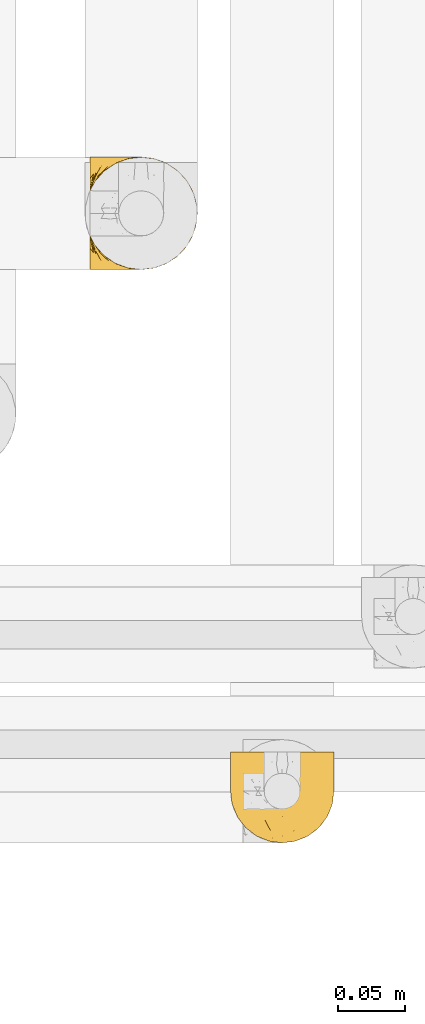
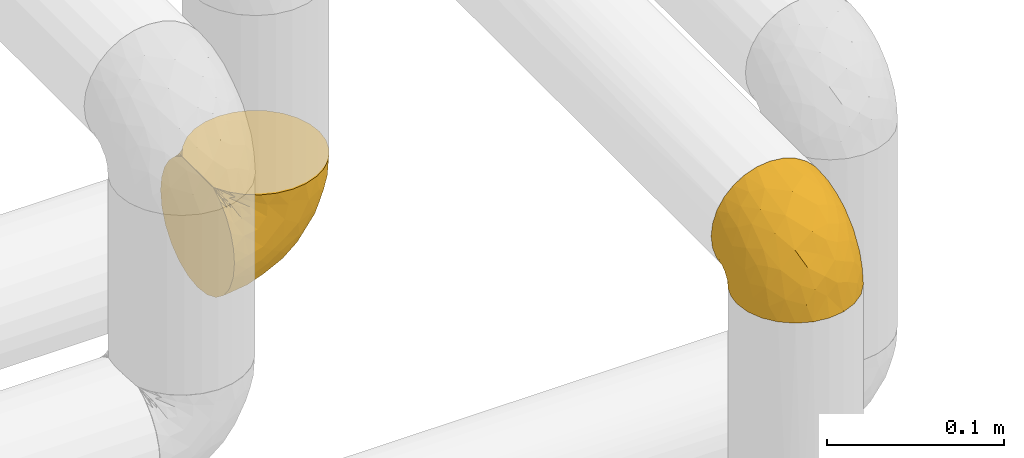
# One storey, part 91 of 827: 2 coverings.
"""IFC2X3 building model written with IfcOpenShell, lengths in millimetres."""

from ifc_helpers import new_model, entity, si_unit, converted_unit, derived_unit, direction, frame, origin, place, context, subcontext, project, spatial, faceted_brep, element, save


model = new_model("IFC2X3")

# Units and contexts
model_context = context("Model", 3, precision=0.01, world=origin(), true_north=direction((6.12303176911189e-17, 1.0)))
body_context = subcontext(model_context, "Body", "Model", "MODEL_VIEW")
ifc_project = project(units=[si_unit("LENGTHUNIT", "METRE", prefix="MILLI"), si_unit("AREAUNIT", "SQUARE_METRE"), si_unit("VOLUMEUNIT", "CUBIC_METRE"), converted_unit("PLANEANGLEUNIT", "DEGREE", entity("IfcRatioMeasure", 0.0174532925199433), si_unit("PLANEANGLEUNIT", "RADIAN"), dimensions=[0, 0, 0, 0, 0, 0, 0]), si_unit("MASSUNIT", "GRAM", prefix="KILO"), derived_unit("MASSDENSITYUNIT", [(si_unit("MASSUNIT", "GRAM", prefix="KILO"), 1), (si_unit("LENGTHUNIT", "METRE"), -3)]), derived_unit("MOMENTOFINERTIAUNIT", [(si_unit("LENGTHUNIT", "METRE"), 4)]), si_unit("TIMEUNIT", "SECOND"), si_unit("FREQUENCYUNIT", "HERTZ"), si_unit("THERMODYNAMICTEMPERATUREUNIT", "DEGREE_CELSIUS"), derived_unit("THERMALTRANSMITTANCEUNIT", [(si_unit("MASSUNIT", "GRAM", prefix="KILO"), 1), (si_unit("THERMODYNAMICTEMPERATUREUNIT", "KELVIN"), -1), (si_unit("TIMEUNIT", "SECOND"), -3)]), derived_unit("VOLUMETRICFLOWRATEUNIT", [(si_unit("LENGTHUNIT", "METRE"), 3), (si_unit("TIMEUNIT", "SECOND"), -1)]), derived_unit("MASSFLOWRATEUNIT", [(si_unit("MASSUNIT", "GRAM", prefix="KILO"), 1), (si_unit("TIMEUNIT", "SECOND"), -1)]), derived_unit("ROTATIONALFREQUENCYUNIT", [(si_unit("TIMEUNIT", "SECOND"), -1)]), si_unit("ELECTRICCURRENTUNIT", "AMPERE"), si_unit("ELECTRICVOLTAGEUNIT", "VOLT"), si_unit("POWERUNIT", "WATT"), si_unit("FORCEUNIT", "NEWTON", prefix="KILO"), si_unit("ILLUMINANCEUNIT", "LUX"), si_unit("LUMINOUSFLUXUNIT", "LUMEN"), si_unit("LUMINOUSINTENSITYUNIT", "CANDELA"), derived_unit("USERDEFINED", [(si_unit("MASSUNIT", "GRAM", prefix="KILO"), -1), (si_unit("LENGTHUNIT", "METRE"), -2), (si_unit("TIMEUNIT", "SECOND"), 3), (si_unit("LUMINOUSFLUXUNIT", "LUMEN"), 1)]), derived_unit("LINEARVELOCITYUNIT", [(si_unit("LENGTHUNIT", "METRE"), 1), (si_unit("TIMEUNIT", "SECOND"), -1)]), si_unit("PRESSUREUNIT", "PASCAL"), derived_unit("USERDEFINED", [(si_unit("LENGTHUNIT", "METRE"), -2), (si_unit("MASSUNIT", "GRAM", prefix="KILO"), 1), (si_unit("TIMEUNIT", "SECOND"), -2)]), derived_unit("LINEARFORCEUNIT", [(si_unit("MASSUNIT", "GRAM", prefix="KILO"), 1), (si_unit("LENGTHUNIT", "METRE"), 1), (si_unit("TIMEUNIT", "SECOND"), -2), (si_unit("LENGTHUNIT", "METRE"), -1)]), derived_unit("PLANARFORCEUNIT", [(si_unit("MASSUNIT", "GRAM", prefix="KILO"), 1), (si_unit("LENGTHUNIT", "METRE"), 1), (si_unit("TIMEUNIT", "SECOND"), -2), (si_unit("LENGTHUNIT", "METRE"), -2)])], contexts=[model_context])

# Site, building, storey
site_placement = place(None, origin())
site = spatial("IfcSite", under=ifc_project, at=site_placement, CompositionType="ELEMENT")
building_placement = place(site_placement, origin())
building = spatial("IfcBuilding", under=site, at=building_placement, CompositionType="ELEMENT")
storey_placement = place(building_placement, frame((0.0, 0.0, 28200.0)))
storey = spatial("IfcBuildingStorey", under=building, at=storey_placement, Name="08", CompositionType="ELEMENT", Elevation=28200.0)

# Coverings
covering_1_placement = place(storey_placement, frame((18545.51, 12779.95, 2569.3)))
element("IfcCovering", 1, at=covering_1_placement, inside=storey, Name=":ADSK_", ObjectType=":ADSK_", PredefinedType="INSULATION", context=body_context, shape_type="Brep", body=[
    faceted_brep([(5.41, 69.15, 47.38), (9.99, 69.15, 54.67), (16.08, 69.15, 60.76), (23.37, 69.15, 65.34), (31.49, 69.15, 68.18), (40.05, 69.15, 69.15), (48.61, 69.15, 68.18), (56.73, 69.15, 65.33), (64.02, 69.15, 60.75), (70.11, 69.15, 54.66), (74.69, 69.15, 47.37), (77.53, 69.15, 39.25), (78.5, 69.15, 30.7), (77.63, 69.15, 22.59), (75.08, 69.15, 14.86), (70.97, 69.15, 7.84), (65.47, 69.15, 1.85), (63.27, 69.15, 1.85), (61.53, 69.15, 1.85), (59.57, 69.15, 1.85), (57.6, 69.15, 1.85), (55.63, 69.15, 1.85), (53.67, 69.15, 1.85), (51.7, 69.15, 1.85), (49.73, 69.15, 1.85), (47.54, 69.15, 1.85), (45.34, 69.15, 1.85), (43.15, 69.15, 1.85), (40.96, 69.15, 1.85), (38.76, 69.15, 1.85), (36.57, 69.15, 1.85), (34.37, 69.15, 1.85), (32.18, 69.15, 1.85), (29.98, 69.15, 1.85), (27.79, 69.15, 1.85), (25.6, 69.15, 1.85), (23.4, 69.15, 1.85), (21.21, 69.15, 1.85), (19.01, 69.15, 1.85), (16.82, 69.15, 1.85), (14.62, 69.15, 1.85), (9.12, 69.15, 7.85), (5.0, 69.15, 14.88), (2.46, 69.15, 22.61), (1.6, 69.15, 30.7), (2.56, 69.15, 39.26), (65.47, 68.89, 1.6), (70.97, 62.89, 1.6), (75.09, 55.87, 1.6), (77.63, 48.14, 1.6), (78.5, 40.05, 1.6), (77.19, 30.09, 1.6), (73.34, 20.82, 1.6), (67.23, 12.86, 1.6), (59.27, 6.75, 1.6), (50.0, 2.91, 1.6), (40.05, 1.6, 1.6), (30.09, 2.91, 1.6), (20.82, 6.75, 1.6), (12.86, 12.86, 1.6), (6.75, 20.82, 1.6), (2.91, 30.09, 1.6), (1.6, 40.05, 1.6), (2.46, 48.14, 1.6), (5.0, 55.87, 1.6), (9.12, 62.89, 1.6), (14.62, 68.89, 1.6), (16.82, 68.89, 1.6), (17.8, 68.89, 1.6), (19.39, 68.89, 1.6), (20.98, 68.89, 1.6), (22.57, 68.89, 1.6), (24.16, 68.89, 1.6), (25.75, 68.89, 1.6), (27.33, 68.89, 1.6), (28.92, 68.89, 1.6), (30.51, 68.89, 1.6), (32.1, 68.89, 1.6), (33.69, 68.89, 1.6), (35.28, 68.89, 1.6), (36.87, 68.89, 1.6), (38.46, 68.89, 1.6), (40.05, 68.89, 1.6), (41.63, 68.89, 1.6), (43.22, 68.89, 1.6), (44.81, 68.89, 1.6), (46.4, 68.89, 1.6), (47.99, 68.89, 1.6), (49.58, 68.89, 1.6), (51.17, 68.89, 1.6), (52.76, 68.89, 1.6), (54.72, 68.89, 1.6), (56.69, 68.89, 1.6), (58.88, 68.89, 1.6), (61.08, 68.89, 1.6), (63.27, 68.89, 1.6), (37.77, 68.97, 1.78), (36.07, 68.96, 1.77), (32.96, 68.97, 1.78), (31.36, 68.97, 1.77), (56.52, 68.98, 1.79), (54.96, 68.97, 1.78), (18.75, 68.96, 1.76), (58.07, 68.96, 1.77), (50.37, 68.96, 1.77), (23.36, 68.96, 1.76), (24.95, 68.96, 1.77), (42.43, 68.96, 1.77), (15.97, 69.0, 1.8), (51.96, 68.96, 1.76), (53.47, 68.96, 1.77), (48.63, 68.97, 1.78), (63.93, 68.96, 1.77), (40.93, 68.96, 1.77), (29.72, 68.96, 1.76), (62.4, 68.97, 1.77), (60.92, 68.97, 1.78), (17.31, 68.97, 1.77), (21.74, 68.96, 1.77), (34.56, 68.96, 1.77), (20.18, 68.97, 1.78), (14.62, 68.97, 1.77), (14.62, 69.02, 1.8), (14.62, 69.08, 1.82), (65.47, 68.97, 1.77), (65.47, 68.94, 1.72), (59.5, 68.96, 1.76), (47.1, 68.96, 1.77), (45.61, 68.95, 1.76), (28.18, 68.96, 1.77), (14.62, 68.92, 1.66), (14.62, 68.94, 1.72), (26.61, 68.98, 1.78), (65.47, 69.08, 1.82), (65.47, 69.02, 1.8), (39.32, 68.96, 1.77), (44.12, 68.97, 1.78), (65.47, 68.92, 1.66), (72.26, 61.33, 3.72), (76.57, 53.1, 7.41), (71.77, 63.33, 6.13), (77.9, 55.53, 19.34), (76.56, 63.33, 17.64), (78.5, 54.6, 26.8), (78.5, 41.99, 8.87), (75.52, 57.07, 9.2), (76.13, 57.95, 12.79), (77.81, 51.56, 14.62), (78.5, 41.58, 7.34), (72.4, 61.7, 5.33), (71.77, 65.0, 7.7), (72.25, 67.02, 9.41), (78.5, 61.87, 28.75), (78.5, 49.27, 21.47), (78.5, 43.94, 16.15), (75.75, 61.21, 14.14), (78.5, 63.4, 29.16), (50.46, 33.11, 57.02), (52.75, 52.82, 64.92), (40.05, 43.3, 64.0), (77.7, 33.73, 11.92), (77.66, 36.52, 19.16), (71.02, 24.87, 28.65), (63.45, 14.17, 24.62), (70.55, 18.43, 15.19), (75.57, 28.67, 18.36), (75.57, 26.0, 9.2), (72.61, 49.25, 46.98), (72.61, 59.72, 50.24), (67.24, 55.1, 56.1), (77.74, 44.72, 28.97), (57.43, 34.15, 54.46), (47.19, 5.25, 21.34), (54.76, 6.75, 18.4), (40.05, 55.54, 66.44), (63.45, 10.47, 12.07), (60.1, 25.49, 45.49), (63.72, 35.53, 50.57), (76.83, 48.22, 36.04), (76.34, 58.71, 42.07), (60.51, 57.42, 62.12), (72.59, 34.84, 37.37), (76.05, 36.87, 29.39), (66.15, 45.01, 53.59), (60.51, 44.4, 58.06), (51.88, 23.96, 49.27), (55.34, 11.2, 29.63), (48.67, 10.56, 33.21), (53.89, 16.81, 40.1), (46.73, 17.38, 44.08), (40.05, 21.38, 49.36), (40.05, 32.34, 56.68), (40.05, 4.3, 15.2), (63.95, 20.65, 35.57), (67.24, 29.66, 41.7), (69.62, 39.6, 46.4), (73.6, 42.55, 41.41), (40.05, 6.74, 27.45), (40.05, 14.06, 38.4), (4.52, 26.84, 12.99), (32.72, 5.28, 21.33), (27.18, 18.52, 42.89), (29.63, 33.13, 57.04), (12.86, 55.1, 56.11), (19.59, 57.43, 62.13), (9.54, 20.72, 21.89), (16.64, 11.46, 16.62), (17.48, 17.69, 32.9), (7.49, 49.26, 46.99), (7.49, 59.73, 50.25), (3.75, 58.71, 42.08), (20.75, 29.72, 49.91), (2.33, 35.35, 15.6), (1.6, 43.94, 16.15), (1.6, 41.99, 8.87), (1.6, 63.4, 29.16), (26.94, 4.93, 13.16), (9.54, 17.46, 10.83), (31.21, 10.94, 33.8), (25.33, 8.92, 25.02), (27.35, 52.83, 64.92), (8.17, 29.34, 32.83), (4.3, 30.26, 20.56), (19.59, 44.4, 58.07), (2.23, 39.06, 21.46), (2.45, 43.06, 28.1), (1.6, 54.6, 26.8), (1.6, 49.27, 21.47), (12.86, 42.69, 51.29), (3.27, 48.2, 36.04), (1.6, 61.87, 28.75), (2.29, 33.44, 8.45), (12.86, 29.67, 41.73), (6.89, 38.5, 39.27), (12.43, 23.35, 33.56), (4.1, 34.97, 27.29), (3.53, 53.1, 7.41), (6.88, 59.68, 3.51), (8.16, 62.19, 4.68), (9.02, 64.11, 5.52), (5.0, 57.97, 8.75), (3.96, 57.95, 12.79), (3.52, 63.33, 17.65), (2.4, 51.77, 13.9), (7.83, 67.02, 9.42), (8.32, 64.98, 7.68), (2.19, 55.53, 19.33), (4.34, 61.22, 14.13)], [[[0, 1, 2, 3, 4, 5, 6, 7, 8, 9, 10, 11, 12, 13, 14, 15, 16, 17, 18, 19, 20, 21, 22, 23, 24, 25, 26, 27, 28, 29, 30, 31, 32, 33, 34, 35, 36, 37, 38, 39, 40, 41, 42, 43, 44, 45]], [[46, 47, 48, 49, 50, 51, 52, 53, 54, 55, 56, 57, 58, 59, 60, 61, 62, 63, 64, 65, 66, 67, 68, 69, 70, 71, 72, 73, 74, 75, 76, 77, 78, 79, 80, 81, 82, 83, 84, 85, 86, 87, 88, 89, 90, 91, 92, 93, 94, 95]], [[96, 97, 30]], [[98, 77, 99]], [[100, 101, 21]], [[69, 68, 102]], [[20, 19, 103]], [[24, 23, 104]], [[20, 103, 100]], [[72, 105, 106]], [[84, 83, 107]], [[89, 88, 104]], [[108, 67, 66]], [[109, 110, 90]], [[111, 25, 24]], [[112, 17, 16]], [[82, 113, 83]], [[109, 23, 22]], [[114, 76, 75]], [[105, 36, 106]], [[104, 111, 24]], [[18, 115, 116]], [[97, 96, 80]], [[67, 108, 117]], [[105, 71, 118]], [[31, 97, 119]], [[102, 120, 69]], [[108, 121, 122, 123, 40]], [[112, 95, 115]], [[17, 115, 18]], [[94, 116, 115]], [[117, 68, 67]], [[38, 117, 39]], [[112, 124, 125]], [[17, 112, 115]], [[70, 120, 118]], [[39, 117, 108]], [[120, 38, 37]], [[120, 37, 118]], [[120, 70, 69]], [[116, 94, 126]], [[127, 86, 128]], [[117, 38, 102]], [[74, 129, 75]], [[99, 33, 32]], [[115, 95, 94]], [[39, 108, 40]], [[108, 66, 130, 131]], [[105, 72, 71]], [[118, 37, 36]], [[71, 70, 118]], [[35, 106, 36]], [[36, 105, 118]], [[35, 132, 106]], [[74, 73, 132]], [[106, 132, 73]], [[99, 114, 33]], [[132, 35, 34]], [[73, 72, 106]], [[95, 112, 46]], [[112, 16, 133, 134, 124]], [[129, 114, 75]], [[99, 76, 114]], [[114, 129, 33]], [[34, 33, 129]], [[78, 77, 98]], [[98, 119, 78]], [[129, 132, 34]], [[132, 129, 74]], [[79, 97, 80]], [[98, 99, 32]], [[98, 32, 31]], [[77, 76, 99]], [[97, 79, 119]], [[135, 96, 29]], [[30, 97, 31]], [[135, 29, 28]], [[81, 80, 96]], [[29, 96, 30]], [[31, 119, 98]], [[119, 79, 78]], [[96, 135, 81]], [[82, 81, 135]], [[113, 107, 83]], [[84, 107, 136]], [[107, 27, 136]], [[113, 28, 107]], [[27, 107, 28]], [[85, 84, 136]], [[136, 27, 26]], [[113, 135, 28]], [[135, 113, 82]], [[109, 89, 104]], [[86, 85, 128]], [[89, 109, 90]], [[111, 87, 127]], [[26, 128, 136]], [[88, 111, 104]], [[25, 111, 127]], [[22, 110, 109]], [[23, 109, 104]], [[110, 91, 90]], [[100, 92, 101]], [[110, 22, 101]], [[91, 110, 101]], [[116, 19, 18]], [[111, 88, 87]], [[126, 103, 19]], [[25, 127, 26]], [[86, 127, 87]], [[127, 128, 26]], [[136, 128, 85]], [[120, 102, 38]], [[117, 102, 68]], [[91, 101, 92]], [[21, 101, 22]], [[93, 92, 103]], [[100, 21, 20]], [[100, 103, 92]], [[126, 93, 103]], [[93, 126, 94]], [[116, 126, 19]], [[137, 138, 47]], [[48, 138, 139]], [[140, 125, 124]], [[141, 142, 143]], [[144, 49, 139]], [[145, 140, 146]], [[48, 139, 49]], [[139, 145, 147]], [[49, 144, 148, 50]], [[137, 125, 149]], [[14, 13, 142]], [[150, 146, 140]], [[149, 140, 145]], [[151, 150, 134]], [[151, 14, 142]], [[16, 15, 133]], [[13, 152, 142]], [[124, 150, 140]], [[141, 143, 153]], [[14, 151, 15]], [[15, 151, 133]], [[47, 46, 137]], [[139, 154, 144]], [[138, 48, 47]], [[125, 140, 149]], [[134, 133, 151]], [[146, 155, 141]], [[145, 146, 147]], [[149, 139, 138]], [[147, 153, 154]], [[147, 146, 141]], [[139, 147, 154]], [[139, 149, 145]], [[149, 138, 137]], [[147, 141, 153]], [[146, 150, 155]], [[151, 155, 150]], [[142, 141, 155]], [[13, 12, 156, 152]], [[152, 143, 142]], [[151, 142, 155]], [[150, 124, 134]], [[157, 158, 159]], [[160, 154, 161]], [[162, 163, 164]], [[165, 166, 160]], [[167, 168, 169]], [[153, 170, 161]], [[156, 12, 11]], [[158, 157, 171]], [[172, 55, 173]], [[158, 6, 174]], [[175, 54, 53]], [[52, 166, 164]], [[52, 164, 53]], [[54, 175, 173]], [[166, 52, 51]], [[176, 177, 171]], [[178, 143, 179]], [[156, 11, 179]], [[8, 7, 180]], [[169, 9, 8]], [[179, 143, 152, 156]], [[179, 11, 10]], [[168, 179, 10]], [[181, 162, 182]], [[179, 167, 178]], [[183, 184, 177]], [[183, 169, 184]], [[176, 171, 185]], [[172, 186, 187]], [[158, 7, 6]], [[159, 158, 174]], [[184, 180, 158]], [[54, 173, 55]], [[180, 169, 8]], [[188, 189, 187]], [[9, 168, 10]], [[186, 188, 187]], [[190, 157, 159, 191]], [[55, 172, 192]], [[176, 193, 194]], [[161, 170, 182]], [[162, 164, 165]], [[175, 164, 163]], [[51, 50, 148]], [[167, 195, 196]], [[178, 182, 170]], [[6, 5, 174]], [[158, 180, 7]], [[169, 180, 184]], [[169, 168, 9]], [[179, 168, 167]], [[182, 162, 165]], [[162, 194, 193]], [[161, 165, 160]], [[195, 181, 196]], [[192, 172, 197]], [[192, 56, 55]], [[189, 190, 198]], [[198, 197, 187]], [[172, 187, 197]], [[185, 189, 188]], [[198, 187, 189]], [[186, 172, 173]], [[173, 163, 186]], [[193, 186, 163]], [[176, 185, 188]], [[185, 157, 190]], [[188, 186, 193]], [[177, 176, 194]], [[188, 193, 176]], [[162, 193, 163]], [[195, 177, 194]], [[171, 177, 184]], [[181, 195, 194]], [[183, 167, 169]], [[162, 181, 194]], [[196, 182, 178]], [[158, 171, 184]], [[171, 157, 185]], [[177, 195, 183]], [[167, 183, 195]], [[182, 196, 181]], [[178, 170, 143]], [[178, 167, 196]], [[164, 175, 53]], [[173, 175, 163]], [[160, 51, 148]], [[164, 166, 165]], [[51, 160, 166]], [[160, 148, 144, 154]], [[153, 161, 154]], [[182, 165, 161]], [[190, 189, 185]], [[143, 170, 153]], [[60, 199, 61]], [[197, 200, 192]], [[201, 190, 202]], [[200, 57, 192]], [[203, 204, 2]], [[205, 206, 207]], [[208, 209, 210]], [[211, 207, 201]], [[212, 213, 214]], [[45, 215, 210]], [[216, 206, 58]], [[45, 44, 215]], [[59, 217, 60]], [[60, 217, 199]], [[0, 45, 210]], [[218, 201, 219]], [[202, 159, 220]], [[205, 221, 222]], [[223, 204, 203]], [[1, 203, 2]], [[57, 200, 216]], [[220, 3, 204]], [[220, 174, 4]], [[1, 0, 209]], [[212, 224, 213]], [[225, 226, 227]], [[228, 223, 203]], [[208, 210, 229]], [[210, 226, 229]], [[3, 220, 4]], [[58, 206, 59]], [[209, 203, 1]], [[202, 220, 223]], [[228, 203, 208]], [[202, 211, 201]], [[3, 2, 204]], [[202, 190, 191, 159]], [[210, 215, 230, 226]], [[199, 212, 231]], [[232, 233, 221]], [[233, 208, 229]], [[207, 206, 219]], [[217, 206, 205]], [[227, 224, 225]], [[233, 232, 228]], [[201, 207, 219]], [[234, 232, 221]], [[218, 219, 200]], [[202, 223, 211]], [[174, 220, 159]], [[174, 5, 4]], [[61, 231, 62]], [[220, 204, 223]], [[210, 209, 0]], [[203, 209, 208]], [[225, 233, 229]], [[224, 227, 213]], [[221, 233, 235]], [[57, 56, 192]], [[198, 218, 197]], [[200, 219, 216]], [[201, 198, 190]], [[197, 218, 200]], [[198, 201, 218]], [[206, 216, 219]], [[58, 57, 216]], [[231, 212, 214]], [[222, 212, 199]], [[228, 211, 223]], [[207, 211, 232]], [[62, 231, 214]], [[199, 231, 61]], [[233, 228, 208]], [[211, 228, 232]], [[222, 221, 235]], [[234, 205, 207]], [[206, 217, 59]], [[199, 217, 205]], [[205, 222, 199]], [[224, 222, 235]], [[222, 224, 212]], [[224, 235, 225]], [[233, 225, 235]], [[226, 225, 229]], [[205, 234, 221]], [[207, 232, 234]], [[63, 214, 236]], [[214, 213, 236]], [[214, 63, 62]], [[237, 236, 238]], [[238, 131, 130]], [[236, 237, 64]], [[239, 240, 241]], [[63, 236, 64]], [[130, 66, 65]], [[237, 130, 65]], [[242, 230, 43]], [[237, 65, 64]], [[239, 121, 131]], [[42, 242, 43]], [[241, 240, 243]], [[41, 123, 244]], [[43, 230, 215, 44]], [[244, 122, 245]], [[227, 246, 243]], [[241, 247, 245]], [[121, 239, 245]], [[41, 40, 123]], [[131, 238, 239]], [[244, 42, 41]], [[130, 237, 238]], [[240, 239, 238]], [[245, 239, 241]], [[247, 241, 246]], [[247, 244, 245]], [[238, 236, 240]], [[243, 236, 213]], [[236, 243, 240]], [[227, 226, 246]], [[243, 213, 227]], [[242, 246, 226]], [[243, 246, 241]], [[246, 242, 247]], [[244, 247, 242]], [[242, 226, 230]], [[42, 244, 242]], [[122, 244, 123]], [[122, 121, 245]], [[112, 125, 137]], [[112, 137, 46]], [[108, 131, 121]]]),
])
covering_2_placement = place(storey_placement, frame((18440.96, 13206.55, 2356.55)))
element("IfcCovering", 2, at=covering_2_placement, inside=storey, Name=":ADSK_", ObjectType=":ADSK_", PredefinedType="INSULATION", context=body_context, shape_type="Brep", body=[
    faceted_brep([(48.91, 2.65, 81.45), (57.76, 5.74, 81.45), (65.69, 10.73, 81.45), (72.32, 17.36, 81.45), (77.3, 25.29, 81.45), (80.4, 34.14, 81.45), (81.45, 43.45, 81.45), (80.39, 52.76, 81.45), (77.3, 61.61, 81.45), (72.31, 69.54, 81.45), (65.68, 76.17, 81.45), (57.75, 81.15, 81.45), (48.9, 84.25, 81.45), (39.6, 85.3, 81.45), (30.22, 84.23, 81.45), (21.33, 81.1, 81.45), (13.37, 76.06, 81.45), (6.73, 69.36, 81.45), (1.77, 61.36, 81.45), (1.77, 60.44, 81.45), (1.77, 59.52, 81.45), (1.77, 58.72, 81.45), (1.77, 57.4, 81.45), (1.77, 56.08, 81.45), (1.77, 54.76, 81.45), (1.77, 53.44, 81.45), (1.77, 52.12, 81.45), (1.77, 50.8, 81.45), (1.77, 49.47, 81.45), (1.77, 48.15, 81.45), (1.77, 46.83, 81.45), (1.77, 45.51, 81.45), (1.77, 44.19, 81.45), (1.77, 42.87, 81.45), (1.77, 41.55, 81.45), (1.77, 40.23, 81.45), (1.77, 39.31, 81.45), (1.77, 38.39, 81.45), (1.77, 37.48, 81.45), (1.77, 36.56, 81.45), (1.77, 35.64, 81.45), (1.77, 34.72, 81.45), (1.77, 33.8, 81.45), (1.77, 32.88, 81.45), (1.77, 31.96, 81.45), (1.77, 31.05, 81.45), (1.77, 30.13, 81.45), (1.77, 29.21, 81.45), (1.77, 28.29, 81.45), (1.77, 27.37, 81.45), (1.77, 26.45, 81.45), (1.77, 25.53, 81.45), (6.74, 17.52, 81.45), (13.38, 10.82, 81.45), (21.35, 5.78, 81.45), (30.24, 2.65, 81.45), (39.6, 1.6, 81.45), (1.6, 69.37, 76.3), (1.6, 76.06, 69.67), (1.6, 81.1, 61.7), (1.6, 84.23, 52.81), (1.6, 85.3, 43.45), (1.6, 83.87, 32.61), (1.6, 79.69, 22.52), (1.61, 73.04, 13.85), (1.61, 64.37, 7.2), (1.61, 54.28, 3.02), (1.61, 43.45, 1.6), (1.61, 32.61, 3.02), (1.61, 22.52, 7.2), (1.61, 13.85, 13.85), (1.6, 7.2, 22.52), (1.6, 3.02, 32.61), (1.6, 1.6, 43.45), (1.6, 2.66, 52.81), (1.6, 5.79, 61.7), (1.6, 10.83, 69.67), (1.6, 17.52, 76.3), (1.6, 25.53, 81.27), (1.6, 26.45, 81.27), (1.6, 27.77, 81.27), (1.6, 28.89, 81.27), (1.6, 30.01, 81.27), (1.6, 31.13, 81.27), (1.6, 32.25, 81.27), (1.6, 33.37, 81.27), (1.6, 34.49, 81.27), (1.6, 35.61, 81.27), (1.6, 36.73, 81.27), (1.6, 37.85, 81.27), (1.6, 38.97, 81.27), (1.6, 40.09, 81.27), (1.6, 41.21, 81.27), (1.6, 42.33, 81.27), (1.6, 43.45, 81.27), (1.6, 44.77, 81.27), (1.6, 46.09, 81.27), (1.6, 47.41, 81.27), (1.6, 48.73, 81.27), (1.6, 50.05, 81.27), (1.6, 51.37, 81.27), (1.6, 52.69, 81.27), (1.6, 54.01, 81.27), (1.6, 54.93, 81.27), (1.6, 55.85, 81.27), (1.6, 56.76, 81.27), (1.6, 57.68, 81.27), (1.6, 58.6, 81.27), (1.6, 59.52, 81.27), (1.6, 60.44, 81.27), (1.6, 61.36, 81.27), (1.71, 32.81, 81.31), (1.73, 31.73, 81.33), (1.71, 50.71, 81.31), (1.72, 51.76, 81.32), (1.71, 42.89, 81.31), (1.72, 41.81, 81.32), (1.72, 25.53, 81.32), (1.72, 26.91, 81.32), (1.72, 40.71, 81.32), (1.72, 60.15, 81.32), (1.72, 39.53, 81.32), (1.72, 57.22, 81.32), (1.7, 58.17, 81.3), (1.72, 47.12, 81.32), (1.73, 33.93, 81.33), (1.72, 35.05, 81.31), (1.73, 46.09, 81.33), (1.73, 45.02, 81.32), (1.72, 43.95, 81.32), (1.72, 59.12, 81.32), (1.71, 38.49, 81.31), (1.72, 49.68, 81.32), (1.71, 53.35, 81.31), (1.72, 54.4, 81.32), (1.72, 56.2, 81.32), (1.72, 36.21, 81.32), (1.73, 37.29, 81.33), (1.72, 30.57, 81.32), (1.71, 29.45, 81.31), (1.73, 28.01, 81.33), (1.72, 61.36, 81.32), (1.74, 25.53, 81.36), (1.75, 25.53, 81.4), (1.75, 61.36, 81.4), (1.74, 61.36, 81.36), (1.64, 25.53, 81.29), (1.68, 25.53, 81.3), (1.68, 61.36, 81.3), (1.64, 61.36, 81.29), (1.74, 55.3, 81.35), (1.71, 48.18, 81.31), (8.98, 82.92, 58.5), (37.05, 85.3, 71.95), (24.69, 82.92, 74.57), (15.28, 78.8, 73.93), (16.86, 78.8, 78.18), (6.58, 70.46, 78.04), (5.71, 71.16, 76.23), (11.1, 85.3, 45.99), (10.79, 76.1, 74.01), (4.13, 72.9, 73.57), (6.62, 78.81, 66.66), (9.52, 72.89, 79.09), (6.14, 74.06, 73.14), (17.79, 83.71, 60.35), (20.6, 85.3, 48.54), (8.74, 85.3, 45.36), (23.66, 83.61, 67.22), (34.51, 85.3, 62.45), (15.32, 80.61, 68.67), (27.55, 85.3, 55.49), (3.31, 67.83, 77.84), (9.81, 78.81, 68.16), (37.68, 85.3, 74.31), (67.23, 54.78, 38.77), (76.64, 57.27, 62.1), (75.37, 43.45, 50.89), (14.58, 84.45, 36.91), (23.72, 84.39, 40.37), (34.35, 77.16, 27.86), (29.11, 68.92, 15.77), (18.03, 76.65, 20.13), (22.27, 82.11, 31.54), (10.98, 82.11, 28.25), (56.79, 78.88, 57.26), (60.76, 78.88, 69.99), (67.04, 73.04, 64.58), (36.11, 84.47, 50.64), (68.85, 65.72, 51.97), (24.59, 51.16, 5.73), (21.55, 59.46, 7.42), (78.4, 43.45, 66.14), (14.12, 68.92, 11.35), (53.43, 51.18, 21.66), (58.19, 57.43, 28.58), (44.49, 83.48, 55.38), (51.77, 82.95, 68.51), (73.69, 65.72, 67.48), (45.89, 78.96, 40.78), (35.98, 82.64, 41.53), (56.55, 75.14, 46.11), (60.03, 68.58, 40.32), (63.65, 61.95, 38.37), (34.99, 58.11, 11.84), (40.59, 51.07, 12.57), (32.16, 43.45, 7.68), (47.26, 58.52, 19.4), (58.06, 43.45, 24.99), (66.72, 43.45, 37.94), (16.92, 43.45, 4.64), (52.08, 65.68, 28.09), (41.21, 70.41, 23.73), (49.76, 73.04, 34.03), (45.11, 43.45, 16.33), (15.65, 4.78, 29.29), (24.58, 35.48, 5.77), (50.55, 29.44, 21.44), (67.25, 32.11, 38.8), (67.06, 13.86, 64.58), (73.7, 21.19, 67.49), (26.13, 10.24, 22.9), (19.55, 17.97, 12.54), (38.97, 18.88, 20.04), (56.8, 8.01, 57.26), (60.77, 8.01, 69.99), (51.78, 3.95, 68.51), (59.09, 22.45, 34.54), (19.26, 2.4, 38.81), (20.6, 1.6, 48.54), (11.1, 1.6, 45.99), (37.68, 1.6, 74.31), (15.22, 29.05, 5.36), (12.77, 10.24, 18.96), (40.94, 35.7, 12.79), (76.65, 29.63, 62.11), (39.5, 8.75, 33.14), (25.02, 4.54, 33.44), (68.86, 21.19, 51.98), (26.7, 2.28, 43.42), (34.95, 2.53, 48.62), (34.51, 1.6, 62.45), (27.55, 1.6, 55.49), (61.27, 13.86, 49.68), (44.5, 3.41, 55.37), (37.05, 1.6, 71.95), (10.26, 2.35, 36.38), (49.78, 13.86, 34.04), (47.51, 7.35, 44.1), (29.39, 27.43, 10.0), (40.01, 13.39, 26.41), (33.37, 4.32, 39.2), (8.98, 3.97, 58.5), (23.67, 3.27, 67.22), (24.71, 3.97, 74.57), (15.29, 8.08, 73.92), (4.13, 13.99, 73.57), (6.14, 12.82, 73.13), (4.96, 8.08, 66.19), (9.81, 8.08, 68.16), (3.31, 19.06, 77.84), (5.7, 15.74, 76.23), (9.53, 13.98, 79.08), (6.59, 16.42, 78.04), (16.63, 8.08, 77.19), (15.34, 6.27, 68.66), (10.8, 10.78, 74.0), (17.79, 3.18, 60.35)], [[[0, 1, 2, 3, 4, 5, 6, 7, 8, 9, 10, 11, 12, 13, 14, 15, 16, 17, 18, 19, 20, 21, 22, 23, 24, 25, 26, 27, 28, 29, 30, 31, 32, 33, 34, 35, 36, 37, 38, 39, 40, 41, 42, 43, 44, 45, 46, 47, 48, 49, 50, 51, 52, 53, 54, 55, 56]], [[57, 58, 59, 60, 61, 62, 63, 64, 65, 66, 67, 68, 69, 70, 71, 72, 73, 74, 75, 76, 77, 78, 79, 80, 81, 82, 83, 84, 85, 86, 87, 88, 89, 90, 91, 92, 93, 94, 95, 96, 97, 98, 99, 100, 101, 102, 103, 104, 105, 106, 107, 108, 109, 110]], [[111, 84, 112]], [[113, 27, 114]], [[114, 101, 100]], [[115, 93, 116]], [[79, 117, 118]], [[34, 116, 119]], [[117, 50, 118]], [[20, 19, 120]], [[91, 121, 119]], [[122, 22, 123]], [[97, 96, 124]], [[86, 125, 126]], [[116, 92, 119]], [[127, 96, 128]], [[33, 129, 115]], [[20, 120, 130]], [[121, 90, 131]], [[94, 115, 129]], [[115, 116, 33]], [[118, 50, 49]], [[113, 99, 132]], [[133, 114, 26]], [[25, 134, 133]], [[135, 23, 122]], [[136, 137, 88]], [[84, 83, 112]], [[138, 82, 139]], [[130, 21, 20]], [[118, 49, 140]], [[81, 140, 139]], [[123, 22, 21]], [[141, 120, 19]], [[139, 82, 81]], [[130, 107, 123]], [[50, 117, 142, 143, 51]], [[19, 18, 144, 145, 141]], [[79, 78, 146, 147, 117]], [[109, 141, 148, 149, 110]], [[102, 133, 134]], [[105, 135, 122]], [[118, 80, 79]], [[80, 118, 140]], [[120, 109, 108]], [[48, 47, 140, 49]], [[81, 80, 140]], [[45, 112, 138]], [[93, 115, 94]], [[47, 139, 140]], [[47, 46, 139]], [[139, 46, 138]], [[138, 112, 83]], [[85, 84, 111]], [[112, 44, 111]], [[83, 82, 138]], [[106, 122, 123]], [[105, 122, 106]], [[22, 122, 23]], [[124, 30, 29]], [[34, 33, 116]], [[128, 129, 32]], [[33, 32, 129]], [[35, 34, 119]], [[116, 93, 92]], [[129, 95, 94]], [[95, 129, 128]], [[91, 119, 92]], [[35, 119, 121]], [[37, 36, 131, 38]], [[137, 131, 89]], [[121, 131, 36]], [[91, 90, 121]], [[42, 41, 125, 43]], [[136, 126, 40]], [[125, 86, 85]], [[43, 125, 111]], [[85, 111, 125]], [[150, 24, 23]], [[130, 108, 107]], [[130, 123, 21]], [[107, 106, 123]], [[137, 38, 131]], [[136, 39, 137]], [[89, 88, 137]], [[131, 90, 89]], [[124, 151, 97]], [[41, 40, 126]], [[87, 126, 136]], [[86, 126, 87]], [[136, 88, 87]], [[41, 126, 125]], [[40, 39, 136]], [[95, 128, 96]], [[31, 128, 32]], [[30, 124, 127]], [[127, 128, 31]], [[151, 124, 29]], [[127, 31, 30]], [[127, 124, 96]], [[151, 98, 97]], [[46, 45, 138]], [[27, 113, 132]], [[113, 100, 99]], [[132, 151, 28]], [[28, 27, 132]], [[27, 26, 114]], [[100, 113, 114]], [[101, 133, 102]], [[133, 101, 114]], [[29, 28, 151]], [[132, 99, 98]], [[24, 134, 25]], [[26, 25, 133]], [[134, 24, 150]], [[135, 104, 150]], [[150, 104, 103]], [[103, 102, 134]], [[130, 120, 108]], [[109, 120, 141]], [[43, 111, 44]], [[112, 45, 44]], [[104, 135, 105]], [[134, 150, 103]], [[135, 150, 23]], [[36, 35, 121]], [[137, 39, 38]], [[98, 151, 132]], [[59, 152, 60]], [[14, 153, 154]], [[155, 156, 154]], [[157, 158, 141]], [[159, 60, 152]], [[160, 157, 155]], [[161, 162, 58]], [[58, 162, 59]], [[144, 17, 163]], [[58, 57, 161]], [[162, 161, 164]], [[157, 163, 155]], [[163, 17, 16]], [[57, 149, 161]], [[152, 165, 166]], [[157, 144, 163]], [[60, 159, 167, 61]], [[156, 15, 154]], [[163, 156, 155]], [[155, 154, 168]], [[168, 154, 169]], [[155, 170, 160]], [[57, 110, 149]], [[144, 18, 17]], [[156, 16, 15]], [[171, 165, 168]], [[158, 164, 172]], [[15, 14, 154]], [[157, 141, 145, 144]], [[173, 164, 158]], [[173, 160, 170]], [[171, 166, 165]], [[168, 165, 170]], [[168, 169, 171]], [[152, 173, 165]], [[170, 155, 168]], [[165, 173, 170]], [[160, 173, 158]], [[172, 149, 148]], [[148, 141, 158]], [[158, 157, 160]], [[152, 166, 159]], [[173, 152, 162]], [[59, 162, 152]], [[14, 13, 174, 153]], [[153, 169, 154]], [[16, 156, 163]], [[162, 164, 173]], [[172, 164, 161]], [[149, 172, 161]], [[158, 172, 148]], [[175, 176, 177]], [[178, 166, 179]], [[180, 181, 182]], [[183, 184, 178]], [[185, 186, 187]], [[171, 188, 179]], [[174, 13, 12]], [[189, 176, 175]], [[190, 66, 191]], [[176, 7, 192]], [[193, 65, 64]], [[63, 184, 182]], [[63, 182, 64]], [[65, 193, 191]], [[184, 63, 62]], [[175, 194, 195]], [[196, 169, 197]], [[174, 12, 197]], [[9, 8, 198]], [[187, 10, 9]], [[197, 169, 153, 174]], [[197, 12, 11]], [[186, 197, 11]], [[199, 180, 200]], [[197, 185, 196]], [[201, 189, 202]], [[201, 187, 189]], [[195, 203, 175]], [[191, 204, 190]], [[176, 8, 7]], [[177, 176, 192]], [[189, 198, 176]], [[65, 191, 66]], [[198, 187, 9]], [[205, 206, 190]], [[10, 186, 11]], [[181, 207, 204]], [[208, 175, 177, 209]], [[66, 190, 210]], [[211, 212, 213]], [[190, 204, 205]], [[62, 61, 167]], [[180, 182, 183]], [[193, 182, 181]], [[196, 185, 199]], [[196, 200, 188]], [[7, 6, 192]], [[176, 198, 8]], [[187, 198, 189]], [[187, 186, 10]], [[197, 186, 185]], [[200, 180, 183]], [[180, 213, 212]], [[179, 183, 178]], [[185, 201, 199]], [[210, 190, 206]], [[210, 67, 66]], [[205, 204, 207]], [[194, 205, 207]], [[194, 214, 205]], [[195, 194, 207]], [[208, 194, 175]], [[207, 211, 195]], [[202, 203, 211]], [[212, 207, 181]], [[202, 211, 213]], [[201, 202, 213]], [[189, 175, 203]], [[199, 201, 213]], [[187, 201, 185]], [[180, 199, 213]], [[196, 199, 200]], [[211, 203, 195]], [[189, 203, 202]], [[207, 212, 211]], [[180, 212, 181]], [[214, 194, 208]], [[214, 206, 205]], [[196, 188, 169]], [[181, 204, 191]], [[182, 193, 64]], [[191, 193, 181]], [[178, 62, 167]], [[182, 184, 183]], [[62, 178, 184]], [[178, 167, 159, 166]], [[171, 179, 166]], [[200, 183, 179]], [[179, 188, 200]], [[169, 188, 171]], [[71, 215, 72]], [[206, 216, 210]], [[217, 208, 218]], [[216, 68, 210]], [[219, 220, 3]], [[221, 222, 223]], [[224, 225, 226]], [[227, 223, 217]], [[228, 229, 230]], [[0, 231, 226]], [[232, 222, 69]], [[0, 56, 231]], [[70, 233, 71]], [[71, 233, 215]], [[1, 0, 226]], [[208, 217, 234]], [[218, 177, 235]], [[221, 236, 237]], [[238, 220, 219]], [[2, 219, 3]], [[68, 216, 232]], [[235, 4, 220]], [[235, 192, 5]], [[2, 1, 225]], [[228, 239, 229]], [[240, 241, 242]], [[243, 238, 219]], [[224, 226, 244]], [[226, 241, 244]], [[4, 235, 5]], [[69, 222, 70]], [[225, 219, 2]], [[218, 235, 238]], [[243, 219, 224]], [[218, 227, 217]], [[4, 3, 220]], [[218, 208, 209, 177]], [[226, 231, 245, 241]], [[215, 228, 246]], [[247, 248, 236]], [[248, 224, 244]], [[223, 222, 249]], [[233, 222, 221]], [[242, 239, 240]], [[248, 247, 243]], [[217, 223, 249]], [[250, 247, 236]], [[216, 234, 249]], [[218, 238, 227]], [[192, 235, 177]], [[192, 6, 5]], [[72, 246, 73]], [[235, 220, 238]], [[226, 225, 1]], [[219, 225, 224]], [[240, 248, 244]], [[239, 242, 229]], [[236, 248, 251]], [[68, 67, 210]], [[234, 216, 206]], [[216, 249, 232]], [[234, 206, 214, 208]], [[249, 234, 217]], [[222, 232, 249]], [[69, 68, 232]], [[246, 228, 230]], [[237, 228, 215]], [[243, 227, 238]], [[223, 227, 247]], [[73, 246, 230]], [[215, 246, 72]], [[248, 243, 224]], [[227, 243, 247]], [[237, 236, 251]], [[250, 221, 223]], [[222, 233, 70]], [[215, 233, 221]], [[221, 237, 215]], [[239, 237, 251]], [[237, 239, 228]], [[239, 251, 240]], [[248, 240, 251]], [[241, 240, 244]], [[221, 250, 236]], [[223, 247, 250]], [[74, 230, 252]], [[253, 254, 255]], [[146, 77, 256]], [[257, 258, 259]], [[260, 256, 257]], [[260, 261, 147]], [[75, 74, 252]], [[52, 143, 262]], [[263, 143, 142, 117]], [[256, 77, 76]], [[252, 258, 75]], [[253, 241, 254]], [[254, 245, 55]], [[258, 256, 76]], [[54, 53, 264]], [[255, 265, 253]], [[254, 264, 255]], [[255, 264, 262]], [[75, 258, 76]], [[265, 255, 266]], [[255, 262, 263]], [[52, 51, 143]], [[55, 245, 231, 56]], [[52, 262, 53]], [[253, 267, 242]], [[254, 55, 54]], [[266, 259, 265]], [[146, 78, 77]], [[263, 117, 261]], [[146, 256, 260]], [[257, 259, 261]], [[267, 253, 265]], [[229, 267, 252]], [[242, 267, 229]], [[242, 241, 253]], [[252, 267, 259]], [[255, 263, 266]], [[259, 267, 265]], [[261, 117, 147]], [[263, 261, 266]], [[259, 266, 261]], [[230, 74, 73]], [[230, 229, 252]], [[259, 258, 252]], [[254, 241, 245]], [[54, 264, 254]], [[53, 262, 264]], [[143, 263, 262]], [[258, 257, 256]], [[261, 260, 257]], [[146, 260, 147]]]),
])

save(model, "model.ifc")
